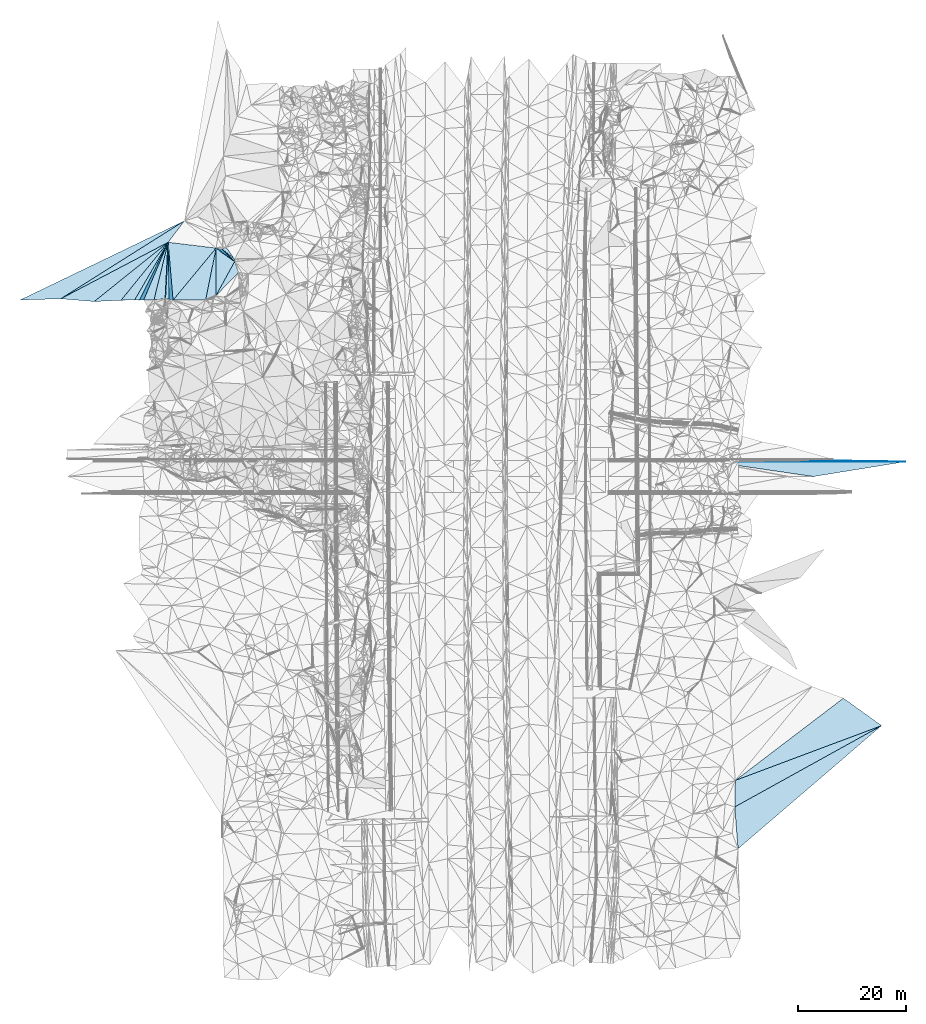
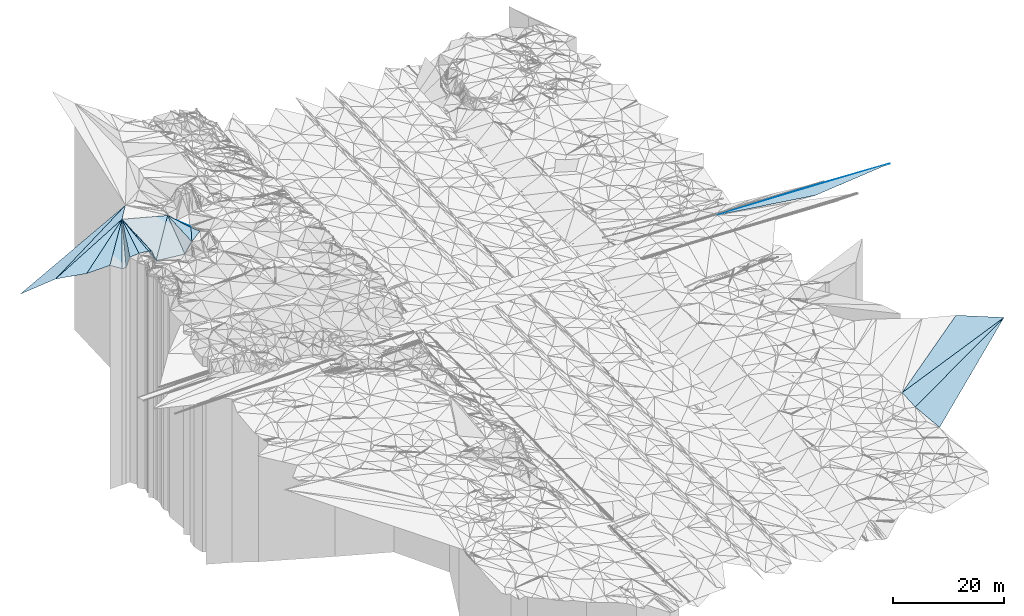
# One storey, part 121 of 275: 24 plates.
"""IFC2X3 building model written with IfcOpenShell, lengths in millimetres."""

from ifc_helpers import new_model, si_unit, frame, origin_with_axes, place, context, subcontext, project, spatial, polyline, outline, extrude, material, type_object, element, save


model = new_model("IFC2X3")

# Units and contexts
model_context = context("Model", 3, precision=1e-05, world=origin_with_axes())
body_context = subcontext(model_context, "Body", "Model", "MODEL_VIEW")
ifc_project = project(units=[si_unit("LENGTHUNIT", "METRE", prefix="MILLI"), si_unit("AREAUNIT", "SQUARE_METRE"), si_unit("VOLUMEUNIT", "CUBIC_METRE"), si_unit("MASSUNIT", "GRAM", prefix="KILO"), si_unit("TIMEUNIT", "SECOND"), si_unit("PLANEANGLEUNIT", "RADIAN"), si_unit("SOLIDANGLEUNIT", "STERADIAN"), si_unit("THERMODYNAMICTEMPERATUREUNIT", "DEGREE_CELSIUS"), si_unit("LUMINOUSINTENSITYUNIT", "LUMEN")], contexts=[model_context])

# Site, building, storey
site_placement = place(None, origin_with_axes())
site = spatial("IfcSite", under=ifc_project, at=site_placement, CompositionType="ELEMENT")
building_placement = place(site_placement, origin_with_axes())
building = spatial("IfcBuilding", under=site, at=building_placement, Name="Undefined", CompositionType="ELEMENT")
storey_placement = place(building_placement, origin_with_axes())
storey = spatial("IfcBuildingStorey", under=building, at=storey_placement, Name="Undefined", CompositionType="ELEMENT", Elevation=0.0)

# Plates
ifc_material = material()
plate_type_1 = type_object("IfcPlateType", PredefinedType="NOTDEFINED")
plate_1_placement = place(storey_placement, frame((-34157.6229937409, 66038.8350071046, 48090.6054438255), z_axis=(-0.0338599635667188, -0.0249758570214547, -0.999114462628434), x_axis=(0.999426275850804, -5.72339860804832e-05, -0.0338690989437899)))
element("IfcPlate", 1, at=plate_1_placement, inside=storey, type_object=plate_type_1, material=ifc_material, Name="00_PR", context=body_context, shape_type="SweptSolid", body=[
    extrude(outline(polyline([(0.0, 0.0), (35931.984375, 4.4150510802865e-08), (18917.283203125, 2750.85864257813), (0.0, 0.0)])), frame((-8.85201319254618e-08, 2.18876761149539e-07, -0.5000001331573), z_axis=(0.0, 0.0, 1.0), x_axis=(1.0, 0.0, 0.0)), (0.0, 0.0, 1.0), 1.0),
])
plate_type_2 = type_object("IfcPlateType", PredefinedType="NOTDEFINED")
plate_2_placement = place(storey_placement, frame((-16201.9224866592, 66287.8058363662, 47475.8634458438), z_axis=(-0.0338599635667188, -0.0249758570214547, -0.999114462628434), x_axis=(0.999340444107103, -0.0139712459880415, -0.0335183689543492)))
element("IfcPlate", 2, at=plate_2_placement, inside=storey, type_object=plate_type_2, material=ifc_material, Name="00_PR", context=body_context, shape_type="SweptSolid", body=[
    extrude(outline(polyline([(0.0, 0.0), (17967.521484375, -8.64383764564991e-09), (-17960.984375, 500.113006591797), (0.0, 0.0)])), frame((-8.85201319254618e-08, 2.18876761149539e-07, -0.5000001331573), z_axis=(0.0, 0.0, 1.0), x_axis=(1.0, 0.0, 0.0)), (0.0, 0.0, 1.0), 1.0),
])
plate_type_3 = type_object("IfcPlateType", PredefinedType="NOTDEFINED")
plate_3_placement = place(storey_placement, frame((-122599.059345641, 103178.447996327, 53789.7741397675), z_axis=(-0.704013406213895, -0.548051457053278, -0.451668821475303), x_axis=(-0.709326442193287, 0.511335922833265, 0.485171693759711)))
element("IfcPlate", 3, at=plate_3_placement, inside=storey, type_object=plate_type_3, material=ifc_material, Name="00", context=body_context, shape_type="SweptSolid", body=[
    extrude(outline(polyline([(0.0, 0.0), (4864.25732421875, -3.04935383610427e-08), (3294.41870117188, 959.430114746094), (0.0, 0.0)])), frame((-8.85201319254618e-08, 2.18876761149539e-07, -0.5000001331573), z_axis=(0.0, 0.0, 1.0), x_axis=(1.0, 0.0, 0.0)), (0.0, 0.0, 1.0), 1.0),
])
plate_type_4 = type_object("IfcPlateType", PredefinedType="NOTDEFINED")
plate_4_placement = place(storey_placement, frame((-137562.600287007, 96071.2138009666, 57639.5022103916), z_axis=(0.0939900087751313, -0.0100934544850053, -0.995521973854425), x_axis=(-0.995557696424058, -0.00652264819487371, -0.0939272492482858)))
element("IfcPlate", 4, at=plate_4_placement, inside=storey, type_object=plate_type_4, material=ifc_material, Name="00", context=body_context, shape_type="SweptSolid", body=[
    extrude(outline(polyline([(0.0, 0.0), (1916.37683105469, 1.70257408171892e-08), (-2688.69360351563, 10649.5029296875), (0.0, 0.0)])), frame((-8.85201319254618e-08, 2.18876761149539e-07, -0.5000001331573), z_axis=(0.0, 0.0, 1.0), x_axis=(1.0, 0.0, 0.0)), (0.0, 0.0, 1.0), 1.0),
])
plate_type_5 = type_object("IfcPlateType", PredefinedType="NOTDEFINED")
plate_5_placement = place(storey_placement, frame((-134944.517964964, 106737.310302867, 57778.8319993772), z_axis=(0.870785576798645, -0.358995039255194, -0.335939043621923), x_axis=(-0.390049385491885, -0.920383374444568, -0.027494016138677)))
element("IfcPlate", 5, at=plate_5_placement, inside=storey, type_object=plate_type_5, material=ifc_material, Name="00", context=body_context, shape_type="SweptSolid", body=[
    extrude(outline(polyline([(0.0, 0.0), (11602.5244140625, -1.41517375595868e-08), (12033.6123046875, 2111.720703125), (0.0, 0.0)])), frame((-8.85201319254618e-08, 2.18876761149539e-07, -0.5000001331573), z_axis=(0.0, 0.0, 1.0), x_axis=(1.0, 0.0, 0.0)), (0.0, 0.0, 1.0), 1.0),
])
plate_type_6 = type_object("IfcPlateType", PredefinedType="NOTDEFINED")
plate_6_placement = place(storey_placement, frame((-2624.50060483773, 17097.8437251365, 44135.5003756281), z_axis=(0.0220811964201904, 0.0320915971535429, -0.999240987028048), x_axis=(-0.874323680774566, -0.484089185617837, -0.0348677731533678)))
element("IfcPlate", 6, at=plate_6_placement, inside=storey, type_object=plate_type_6, material=ifc_material, Name="00", context=body_context, shape_type="SweptSolid", body=[
    extrude(outline(polyline([(0.0, 0.0), (31146.240234375, 1.02481862995774e-08), (28673.177734375, 4247.171875), (0.0, 0.0)])), frame((-8.85201319254618e-08, 2.18876761149539e-07, -0.5000001331573), z_axis=(0.0, 0.0, 1.0), x_axis=(1.0, 0.0, 0.0)), (0.0, 0.0, 1.0), 1.0),
])
plate_type_7 = type_object("IfcPlateType", PredefinedType="NOTDEFINED")
plate_7_placement = place(storey_placement, frame((-140270.78582542, 95989.3415191092, 55459.5180642173), z_axis=(-0.0881326078978456, 0.251616356145567, -0.963805920683802), x_axis=(-0.994232495952134, 0.0371385883536341, 0.100610482793237)))
element("IfcPlate", 7, at=plate_7_placement, inside=storey, type_object=plate_type_7, material=ifc_material, Name="00", context=body_context, shape_type="SweptSolid", body=[
    extrude(outline(polyline([(0.0, 0.0), (894.539001464844, -5.51517587155104e-09), (-4662.58056640625, 11292.80859375), (0.0, 0.0)])), frame((-8.85201319254618e-08, 2.18876761149539e-07, -0.5000001331573), z_axis=(0.0, 0.0, 1.0), x_axis=(1.0, 0.0, 0.0)), (0.0, 0.0, 1.0), 1.0),
])
plate_type_8 = type_object("IfcPlateType", PredefinedType="NOTDEFINED")
plate_8_placement = place(storey_placement, frame((-122631.525024717, 103623.484024732, 53839.5358898672), z_axis=(-0.368907376224932, -0.0490801867891579, -0.928169425822451), x_axis=(-0.751800211159448, 0.602948908806826, 0.266925187776026)))
element("IfcPlate", 8, at=plate_8_placement, inside=storey, type_object=plate_type_8, material=ifc_material, Name="00", context=body_context, shape_type="SweptSolid", body=[
    extrude(outline(polyline([(0.0, 0.0), (3109.48559570313, 5.24596543982625e-09), (2568.62426757813, 754.366760253906), (0.0, 0.0)])), frame((-8.85201319254618e-08, 2.18876761149539e-07, -0.5000001331573), z_axis=(0.0, 0.0, 1.0), x_axis=(1.0, 0.0, 0.0)), (0.0, 0.0, 1.0), 1.0),
])
plate_type_9 = type_object("IfcPlateType", PredefinedType="NOTDEFINED")
plate_9_placement = place(storey_placement, frame((-126048.72853684, 105666.006472847, 56149.6204623464), z_axis=(0.650386679706406, 0.0297987322470899, -0.759018578439911), x_axis=(-0.00550768877803874, -0.999018969417968, -0.0439404609373404)))
element("IfcPlate", 9, at=plate_9_placement, inside=storey, type_object=plate_type_9, material=ifc_material, Name="00", context=body_context, shape_type="SweptSolid", body=[
    extrude(outline(polyline([(0.0, 0.0), (8875.646484375, 1.49302650243044e-08), (9700.9384765625, 2468.86474609375), (0.0, 0.0)])), frame((-8.85201319254618e-08, 2.18876761149539e-07, -0.5000001331573), z_axis=(0.0, 0.0, 1.0), x_axis=(1.0, 0.0, 0.0)), (0.0, 0.0, 1.0), 1.0),
])
plate_type_10 = type_object("IfcPlateType", PredefinedType="NOTDEFINED")
plate_10_placement = place(storey_placement, frame((-134945.159816087, 106737.521297964, 57778.5456973287), z_axis=(-0.413006388276375, 0.0629697505932797, -0.908548586346996), x_axis=(0.0135882102029304, -0.997069706010152, -0.0752818829487496)))
element("IfcPlate", 10, at=plate_10_placement, inside=storey, type_object=plate_type_10, material=ifc_material, Name="00", context=body_context, shape_type="SweptSolid", body=[
    extrude(outline(polyline([(0.0, 0.0), (10613.443359375, 1.75205059349537e-08), (10482.55078125, 730.388366699219), (0.0, 0.0)])), frame((-8.85201319254618e-08, 2.18876761149539e-07, -0.5000001331573), z_axis=(0.0, 0.0, 1.0), x_axis=(1.0, 0.0, 0.0)), (0.0, 0.0, 1.0), 1.0),
])
plate_type_11 = type_object("IfcPlateType", PredefinedType="NOTDEFINED")
plate_11_placement = place(storey_placement, frame((-124969.187399894, 105498.41343059, 54669.5205373874), z_axis=(-0.269875741650616, 0.0879891867700169, -0.958866511606324), x_axis=(0.751800211393383, -0.602948908477723, -0.266925187860545)))
element("IfcPlate", 11, at=plate_11_placement, inside=storey, type_object=plate_type_11, material=ifc_material, Name="00", context=body_context, shape_type="SweptSolid", body=[
    extrude(outline(polyline([(0.0, 0.0), (3109.48559570313, 5.24596543982625e-09), (3415.54907226563, 328.215087890625), (0.0, 0.0)])), frame((-8.85201319254618e-08, 2.18876761149539e-07, -0.5000001331573), z_axis=(0.0, 0.0, 1.0), x_axis=(1.0, 0.0, 0.0)), (0.0, 0.0, 1.0), 1.0),
])
plate_type_12 = type_object("IfcPlateType", PredefinedType="NOTDEFINED")
plate_12_placement = place(storey_placement, frame((-143678.512158699, 95980.8960034163, 57169.6242383146), z_axis=(-0.490753102876875, 0.440980201821587, -0.751463807257616), x_axis=(0.629697782741563, 0.775598190037586, 0.043910705081782)))
element("IfcPlate", 12, at=plate_12_placement, inside=storey, type_object=plate_type_12, material=ifc_material, Name="00", context=body_context, shape_type="SweptSolid", body=[
    extrude(outline(polyline([(0.0, 0.0), (13869.0556640625, -8.32951627671719e-08), (1546.92578125, 2564.02416992188), (0.0, 0.0)])), frame((-8.85201319254618e-08, 2.18876761149539e-07, -0.5000001331573), z_axis=(0.0, 0.0, 1.0), x_axis=(1.0, 0.0, 0.0)), (0.0, 0.0, 1.0), 1.0),
])
plate_type_13 = type_object("IfcPlateType", PredefinedType="NOTDEFINED")
plate_13_placement = place(storey_placement, frame((-134945.424922808, 106737.495916894, 57778.8340045366), z_axis=(-0.943223493539048, 0.012207696168442, -0.331934351024797), x_axis=(0.0820528292503131, -0.959789950181167, -0.26845965198378)))
element("IfcPlate", 13, at=plate_13_placement, inside=storey, type_object=plate_type_13, material=ifc_material, Name="00", context=body_context, shape_type="SweptSolid", body=[
    extrude(outline(polyline([(0.0, 0.0), (11171.138671875, 6.37955963611603e-08), (10383.1591796875, 2198.90600585938), (0.0, 0.0)])), frame((-8.85201319254618e-08, 2.18876761149539e-07, -0.5000001331573), z_axis=(0.0, 0.0, 1.0), x_axis=(1.0, 0.0, 0.0)), (0.0, 0.0, 1.0), 1.0),
])
plate_type_14 = type_object("IfcPlateType", PredefinedType="NOTDEFINED")
plate_14_placement = place(storey_placement, frame((-134028.401949454, 96015.6707354942, 54779.5219304211), z_axis=(-0.144351877069386, 0.25508222366537, -0.956083466417276), x_axis=(-0.0820528292403299, 0.959789950181484, 0.268459651985699)))
element("IfcPlate", 14, at=plate_14_placement, inside=storey, type_object=plate_type_14, material=ifc_material, Name="00", context=body_context, shape_type="SweptSolid", body=[
    extrude(outline(polyline([(0.0, 0.0), (11171.138671875, 6.37955963611603e-08), (8975.470703125, 8838.4287109375), (0.0, 0.0)])), frame((-8.85201319254618e-08, 2.18876761149539e-07, -0.5000001331573), z_axis=(0.0, 0.0, 1.0), x_axis=(1.0, 0.0, 0.0)), (0.0, 0.0, 1.0), 1.0),
])
plate_type_15 = type_object("IfcPlateType", PredefinedType="NOTDEFINED")
plate_15_placement = place(storey_placement, frame((-126049.107271892, 105666.104566136, 56149.5158648352), z_axis=(-0.107105082519775, 0.226008312537904, -0.968219367685961), x_axis=(-0.19267787469138, -0.960078083665877, -0.202793761908179)))
element("IfcPlate", 15, at=plate_15_placement, inside=storey, type_object=plate_type_15, material=ifc_material, Name="00", context=body_context, shape_type="SweptSolid", body=[
    extrude(outline(polyline([(0.0, 0.0), (10010.169921875, -2.49419827014208e-08), (11080.44140625, 5991.720703125), (0.0, 0.0)])), frame((-8.85201319254618e-08, 2.18876761149539e-07, -0.5000001331573), z_axis=(0.0, 0.0, 1.0), x_axis=(1.0, 0.0, 0.0)), (0.0, 0.0, 1.0), 1.0),
])
plate_type_16 = type_object("IfcPlateType", PredefinedType="NOTDEFINED")
plate_16_placement = place(storey_placement, frame((-126098.210213236, 96799.0723170722, 55759.5810285881), z_axis=(-0.544378935470867, 0.0398547336803398, -0.837892102134204), x_axis=(0.00550768878981548, 0.99901896941665, 0.0439404609658279)))
element("IfcPlate", 16, at=plate_16_placement, inside=storey, type_object=plate_type_16, material=ifc_material, Name="00", context=body_context, shape_type="SweptSolid", body=[
    extrude(outline(polyline([(0.0, 0.0), (8875.646484375, 1.49302650243044e-08), (6306.12109375, 4130.1982421875), (0.0, 0.0)])), frame((-8.85201319254618e-08, 2.18876761149539e-07, -0.5000001331573), z_axis=(0.0, 0.0, 1.0), x_axis=(1.0, 0.0, 0.0)), (0.0, 0.0, 1.0), 1.0),
])
plate_type_17 = type_object("IfcPlateType", PredefinedType="NOTDEFINED")
plate_17_placement = place(storey_placement, frame((-126098.053555794, 96798.9678260197, 55759.5209126562), z_axis=(-0.231064470924165, -0.16912488573696, -0.958126287762211), x_axis=(0.464194700034611, 0.84630282839581, -0.261332744042974)))
element("IfcPlate", 17, at=plate_17_placement, inside=storey, type_object=plate_type_17, material=ifc_material, Name="00", context=body_context, shape_type="SweptSolid", body=[
    extrude(outline(polyline([(0.0, 0.0), (7538.2822265625, 1.54832378029823e-08), (6089.9814453125, 1610.41137695313), (0.0, 0.0)])), frame((-8.85201319254618e-08, 2.18876761149539e-07, -0.5000001331573), z_axis=(0.0, 0.0, 1.0), x_axis=(1.0, 0.0, 0.0)), (0.0, 0.0, 1.0), 1.0),
])
plate_type_18 = type_object("IfcPlateType", PredefinedType="NOTDEFINED")
plate_18_placement = place(storey_placement, frame((-134945.037933111, 106737.516967362, 57778.50792223), z_axis=(-0.169143833176832, 0.0543353573212499, -0.984092491914769), x_axis=(-0.049740558338847, -0.997677435808538, -0.0465361250497003)))
element("IfcPlate", 18, at=plate_18_placement, inside=storey, type_object=plate_type_18, material=ifc_material, Name="00", context=body_context, shape_type="SweptSolid", body=[
    extrude(outline(polyline([(0.0, 0.0), (10507.9658203125, -6.46105036139488e-08), (10778.171875, 2114.70776367188), (0.0, 0.0)])), frame((-8.85201319254618e-08, 2.18876761149539e-07, -0.5000001331573), z_axis=(0.0, 0.0, 1.0), x_axis=(1.0, 0.0, 0.0)), (0.0, 0.0, 1.0), 1.0),
])
plate_type_19 = type_object("IfcPlateType", PredefinedType="NOTDEFINED")
plate_19_placement = place(storey_placement, frame((-154857.752559616, 96264.6628795602, 57919.5082837101), z_axis=(-0.0899629042610709, 0.157812465089062, -0.983362548462889), x_axis=(0.885038031110602, 0.465476540768563, -0.00626685583056452)))
element("IfcPlate", 19, at=plate_19_placement, inside=storey, type_object=plate_type_19, material=ifc_material, Name="00", context=body_context, shape_type="SweptSolid", body=[
    extrude(outline(polyline([(0.0, 0.0), (22499.3203125, -3.12342308461666e-07), (5239.1513671875, 3399.51391601563), (0.0, 0.0)])), frame((-8.85201319254618e-08, 2.18876761149539e-07, -0.5000001331573), z_axis=(0.0, 0.0, 1.0), x_axis=(1.0, 0.0, 0.0)), (0.0, 0.0, 1.0), 1.0),
])
plate_type_20 = type_object("IfcPlateType", PredefinedType="NOTDEFINED")
plate_20_placement = place(storey_placement, frame((-148668.166435057, 95742.7650276982, 57269.5015360035), z_axis=(-0.0235818904060613, 0.0755833575179605, -0.996860597331035), x_axis=(0.780092421910249, 0.62499490974057, 0.0289339951714055)))
element("IfcPlate", 20, at=plate_20_placement, inside=storey, type_object=plate_type_20, material=ifc_material, Name="00", context=body_context, shape_type="SweptSolid", body=[
    extrude(outline(polyline([(0.0, 0.0), (17591.763671875, -1.1164229363203e-07), (4038.39672851563, 2942.26977539063), (0.0, 0.0)])), frame((-8.85201319254618e-08, 2.18876761149539e-07, -0.5000001331573), z_axis=(0.0, 0.0, 1.0), x_axis=(1.0, 0.0, 0.0)), (0.0, 0.0, 1.0), 1.0),
])
plate_type_21 = type_object("IfcPlateType", PredefinedType="NOTDEFINED")
plate_21_placement = place(storey_placement, frame((-29753.3387005307, 6931.31465805803, 43209.5002549923), z_axis=(0.0279350701747043, 0.016492028242254, -0.99947368392509), x_axis=(0.795266279316733, 0.605403669296399, 0.0322171101152301)))
element("IfcPlate", 21, at=plate_21_placement, inside=storey, type_object=plate_type_21, material=ifc_material, Name="00", context=body_context, shape_type="SweptSolid", body=[
    extrude(outline(polyline([(0.0, 0.0), (25203.998046875, -2.32976162806153e-08), (27759.333984375, 8343.19921875), (0.0, 0.0)])), frame((-8.85201319254618e-08, 2.18876761149539e-07, -0.5000001331573), z_axis=(0.0, 0.0, 1.0), x_axis=(1.0, 0.0, 0.0)), (0.0, 0.0, 1.0), 1.0),
])
plate_type_22 = type_object("IfcPlateType", PredefinedType="NOTDEFINED")
plate_22_placement = place(storey_placement, frame((-29856.3871149081, 2020.27073875978, 43049.5003702927), z_axis=(0.0388901617133731, 0.00173264284054307, -0.999241989345271), x_axis=(0.874323680774444, 0.484089185618995, 0.0348677731403438)))
element("IfcPlate", 22, at=plate_22_placement, inside=storey, type_object=plate_type_22, material=ifc_material, Name="00", context=body_context, shape_type="SweptSolid", body=[
    extrude(outline(polyline([(0.0, 0.0), (31146.240234375, 1.02481862995774e-08), (-3233.53833007813, 7090.4814453125), (0.0, 0.0)])), frame((-8.85201319254618e-08, 2.18876761149539e-07, -0.5000001331573), z_axis=(0.0, 0.0, 1.0), x_axis=(1.0, 0.0, 0.0)), (0.0, 0.0, 1.0), 1.0),
])
plate_type_23 = type_object("IfcPlateType", PredefinedType="NOTDEFINED")
plate_23_placement = place(storey_placement, frame((-162417.399349819, 96027.5380410776, 57339.5083299386), z_axis=(0.080558918210186, -0.163328698133873, -0.983277172043925), x_axis=(0.900965205644783, 0.433887840417166, 0.00174360419325557)))
element("IfcPlate", 23, at=plate_23_placement, inside=storey, type_object=plate_type_23, material=ifc_material, Name="00", context=body_context, shape_type="SweptSolid", body=[
    extrude(outline(polyline([(0.0, 0.0), (33837.96875, 2.32888851314783e-07), (6914.8828125, 3118.73315429688), (0.0, 0.0)])), frame((-8.85201319254618e-08, 2.18876761149539e-07, -0.5000001331573), z_axis=(0.0, 0.0, 1.0), x_axis=(1.0, 0.0, 0.0)), (0.0, 0.0, 1.0), 1.0),
])
plate_type_24 = type_object("IfcPlateType", PredefinedType="NOTDEFINED")
plate_24_placement = place(storey_placement, frame((-131930.572304528, 110709.428490128, 57398.5067743621), z_axis=(0.0709767114934047, -0.148232453675533, -0.98640227397493), x_axis=(-0.602777925884243, -0.794282392693031, 0.0759885038971306)))
element("IfcPlate", 24, at=plate_24_placement, inside=storey, type_object=plate_type_24, material=ifc_material, Name="00", context=body_context, shape_type="SweptSolid", body=[
    extrude(outline(polyline([(0.0, 0.0), (5000.75634765625, -4.83705662190914e-08), (25332.884765625, 9634.521484375), (0.0, 0.0)])), frame((-8.85201319254618e-08, 2.18876761149539e-07, -0.5000001331573), z_axis=(0.0, 0.0, 1.0), x_axis=(1.0, 0.0, 0.0)), (0.0, 0.0, 1.0), 1.0),
])

save(model, "model.ifc")
